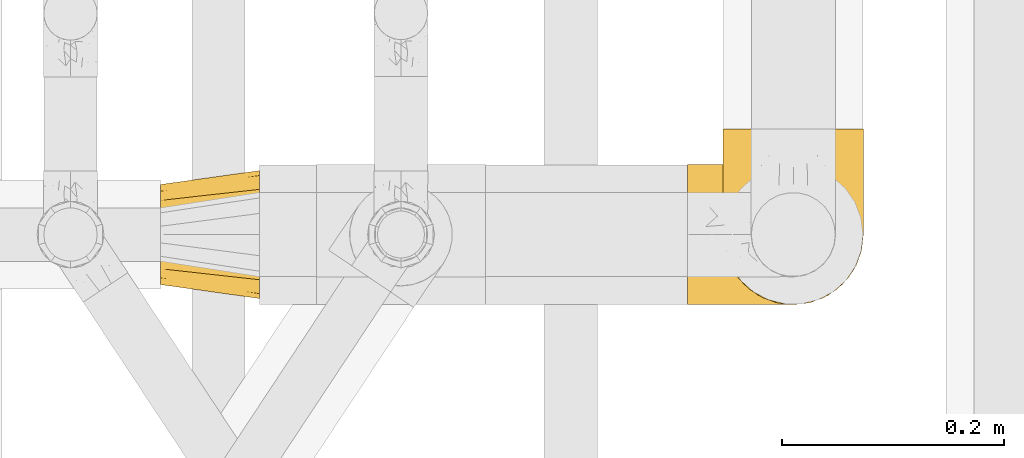
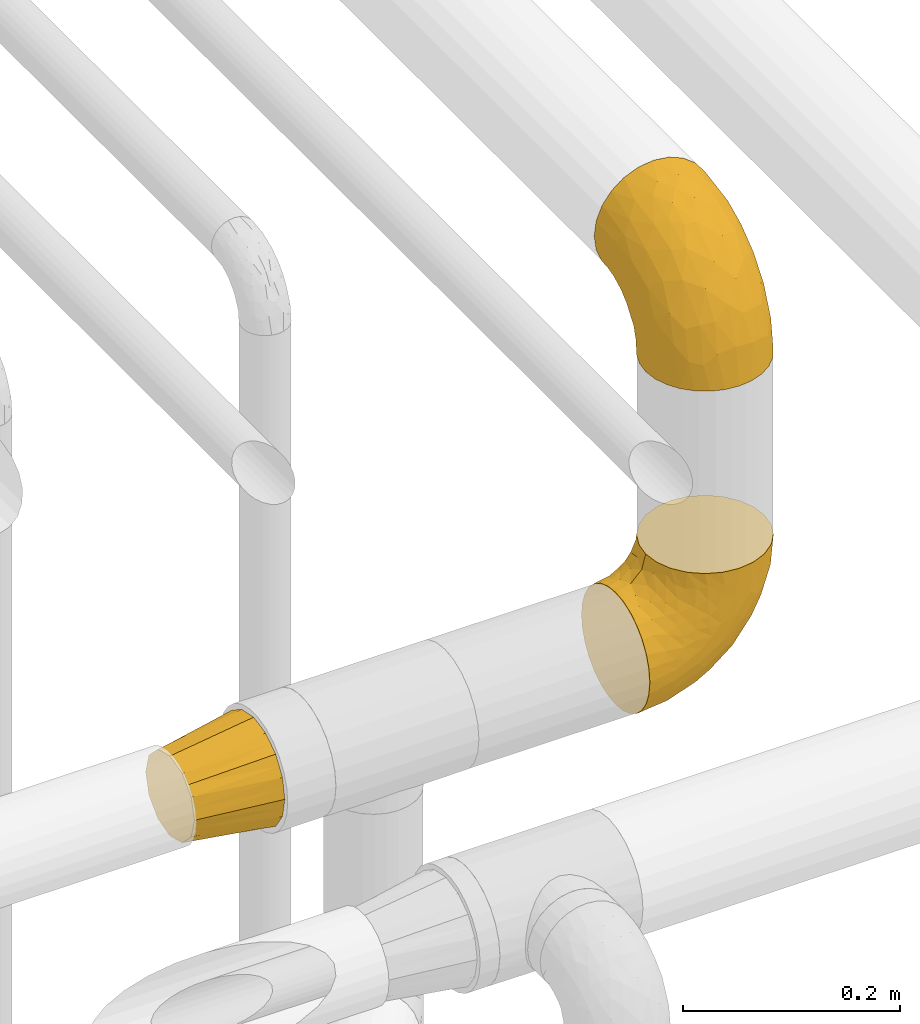
# One storey, part 389 of 827: 3 coverings.
"""IFC2X3 building model written with IfcOpenShell, lengths in millimetres."""

from ifc_helpers import new_model, entity, si_unit, converted_unit, derived_unit, direction, frame, origin, place, context, subcontext, project, spatial, faceted_brep, element, save


model = new_model("IFC2X3")

# Units and contexts
model_context = context("Model", 3, precision=0.01, world=origin(), true_north=direction((6.12303176911189e-17, 1.0)))
body_context = subcontext(model_context, "Body", "Model", "MODEL_VIEW")
ifc_project = project(units=[si_unit("LENGTHUNIT", "METRE", prefix="MILLI"), si_unit("AREAUNIT", "SQUARE_METRE"), si_unit("VOLUMEUNIT", "CUBIC_METRE"), converted_unit("PLANEANGLEUNIT", "DEGREE", entity("IfcRatioMeasure", 0.0174532925199433), si_unit("PLANEANGLEUNIT", "RADIAN"), dimensions=[0, 0, 0, 0, 0, 0, 0]), si_unit("MASSUNIT", "GRAM", prefix="KILO"), derived_unit("MASSDENSITYUNIT", [(si_unit("MASSUNIT", "GRAM", prefix="KILO"), 1), (si_unit("LENGTHUNIT", "METRE"), -3)]), derived_unit("MOMENTOFINERTIAUNIT", [(si_unit("LENGTHUNIT", "METRE"), 4)]), si_unit("TIMEUNIT", "SECOND"), si_unit("FREQUENCYUNIT", "HERTZ"), si_unit("THERMODYNAMICTEMPERATUREUNIT", "DEGREE_CELSIUS"), derived_unit("THERMALTRANSMITTANCEUNIT", [(si_unit("MASSUNIT", "GRAM", prefix="KILO"), 1), (si_unit("THERMODYNAMICTEMPERATUREUNIT", "KELVIN"), -1), (si_unit("TIMEUNIT", "SECOND"), -3)]), derived_unit("VOLUMETRICFLOWRATEUNIT", [(si_unit("LENGTHUNIT", "METRE"), 3), (si_unit("TIMEUNIT", "SECOND"), -1)]), derived_unit("MASSFLOWRATEUNIT", [(si_unit("MASSUNIT", "GRAM", prefix="KILO"), 1), (si_unit("TIMEUNIT", "SECOND"), -1)]), derived_unit("ROTATIONALFREQUENCYUNIT", [(si_unit("TIMEUNIT", "SECOND"), -1)]), si_unit("ELECTRICCURRENTUNIT", "AMPERE"), si_unit("ELECTRICVOLTAGEUNIT", "VOLT"), si_unit("POWERUNIT", "WATT"), si_unit("FORCEUNIT", "NEWTON", prefix="KILO"), si_unit("ILLUMINANCEUNIT", "LUX"), si_unit("LUMINOUSFLUXUNIT", "LUMEN"), si_unit("LUMINOUSINTENSITYUNIT", "CANDELA"), derived_unit("USERDEFINED", [(si_unit("MASSUNIT", "GRAM", prefix="KILO"), -1), (si_unit("LENGTHUNIT", "METRE"), -2), (si_unit("TIMEUNIT", "SECOND"), 3), (si_unit("LUMINOUSFLUXUNIT", "LUMEN"), 1)]), derived_unit("LINEARVELOCITYUNIT", [(si_unit("LENGTHUNIT", "METRE"), 1), (si_unit("TIMEUNIT", "SECOND"), -1)]), si_unit("PRESSUREUNIT", "PASCAL"), derived_unit("USERDEFINED", [(si_unit("LENGTHUNIT", "METRE"), -2), (si_unit("MASSUNIT", "GRAM", prefix="KILO"), 1), (si_unit("TIMEUNIT", "SECOND"), -2)]), derived_unit("LINEARFORCEUNIT", [(si_unit("MASSUNIT", "GRAM", prefix="KILO"), 1), (si_unit("LENGTHUNIT", "METRE"), 1), (si_unit("TIMEUNIT", "SECOND"), -2), (si_unit("LENGTHUNIT", "METRE"), -1)]), derived_unit("PLANARFORCEUNIT", [(si_unit("MASSUNIT", "GRAM", prefix="KILO"), 1), (si_unit("LENGTHUNIT", "METRE"), 1), (si_unit("TIMEUNIT", "SECOND"), -2), (si_unit("LENGTHUNIT", "METRE"), -2)])], contexts=[model_context])

# Site, building, storey
site_placement = place(None, origin())
site = spatial("IfcSite", under=ifc_project, at=site_placement, CompositionType="ELEMENT")
building_placement = place(site_placement, origin())
building = spatial("IfcBuilding", under=site, at=building_placement, CompositionType="ELEMENT")
storey_placement = place(building_placement, frame((0.0, 0.0, 28200.0)))
storey = spatial("IfcBuildingStorey", under=building, at=storey_placement, Name="08", CompositionType="ELEMENT", Elevation=28200.0)

# Coverings
covering_1_placement = place(storey_placement, frame((48580.2, 14171.03, 2903.4)))
element("IfcCovering", 1, at=covering_1_placement, inside=storey, Name=":ADSK_", ObjectType=":ADSK_", PredefinedType="INSULATION", context=body_context, shape_type="Brep", body=[
    faceted_brep([(126.11, 50.62, 1.6), (121.45, 37.29, 1.6), (113.94, 25.34, 1.6), (103.96, 15.35, 1.6), (92.0, 7.84, 1.6), (78.68, 3.18, 1.6), (64.65, 1.6, 1.6), (50.62, 3.18, 1.6), (37.29, 7.84, 1.6), (25.34, 15.35, 1.6), (15.35, 25.33, 1.6), (7.84, 37.29, 1.6), (3.18, 50.61, 1.6), (1.6, 64.65, 1.6), (3.18, 78.67, 1.6), (7.84, 92.0, 1.6), (15.35, 103.95, 1.6), (25.33, 113.94, 1.6), (37.29, 121.45, 1.6), (50.61, 126.11, 1.6), (64.65, 127.7, 1.6), (78.67, 126.11, 1.6), (92.0, 121.45, 1.6), (103.95, 113.94, 1.6), (113.94, 103.96, 1.6), (121.45, 92.0, 1.6), (126.11, 78.68, 1.6), (127.7, 64.65, 1.6), (64.65, 159.65, 33.55), (48.33, 159.65, 35.69), (33.12, 159.65, 41.99), (20.06, 159.65, 52.01), (10.04, 159.65, 65.07), (3.74, 159.65, 80.28), (3.01, 159.65, 85.89), (1.6, 159.65, 96.6), (3.74, 159.65, 112.91), (10.04, 159.65, 128.12), (20.06, 159.65, 141.18), (33.12, 159.65, 151.2), (48.33, 159.65, 157.5), (64.65, 159.65, 159.65), (80.96, 159.65, 157.5), (96.17, 159.65, 151.2), (109.23, 159.65, 141.18), (119.25, 159.65, 128.12), (125.55, 159.65, 112.91), (127.7, 159.65, 96.6), (126.29, 159.65, 85.89), (125.55, 159.65, 80.28), (119.25, 159.65, 65.07), (109.23, 159.65, 52.01), (96.17, 159.65, 41.99), (80.96, 159.65, 35.69), (101.1, 131.11, 145.23), (86.72, 121.84, 150.95), (98.7, 98.59, 136.48), (75.93, 132.73, 156.3), (64.65, 118.74, 154.26), (113.39, 45.67, 73.92), (111.06, 62.3, 98.94), (96.87, 49.95, 102.72), (84.07, 65.74, 124.89), (64.65, 80.62, 138.47), (64.65, 47.89, 113.35), (119.56, 117.53, 120.33), (112.75, 90.48, 118.42), (122.85, 98.53, 103.99), (125.08, 128.08, 110.05), (126.64, 107.83, 94.6), (105.78, 30.59, 62.68), (93.81, 23.56, 66.8), (96.07, 14.41, 37.71), (87.11, 94.66, 141.12), (75.77, 103.54, 148.29), (111.99, 121.36, 132.76), (64.65, 6.98, 42.5), (83.58, 9.17, 39.36), (80.96, 35.7, 96.16), (78.34, 18.43, 69.16), (122.85, 57.25, 62.71), (125.88, 81.84, 79.4), (120.97, 72.43, 88.81), (126.67, 56.38, 26.93), (122.64, 43.86, 32.13), (127.7, 103.81, 78.45), (127.7, 117.05, 85.2), (127.7, 130.29, 91.95), (107.12, 21.28, 31.66), (115.07, 34.21, 45.38), (102.81, 74.07, 118.88), (127.7, 82.79, 57.43), (127.7, 88.04, 62.69), (127.7, 93.3, 67.94), (127.7, 66.61, 13.99), (127.7, 67.95, 22.47), (127.7, 69.29, 30.95), (126.64, 66.64, 53.41), (127.7, 76.04, 44.19), (64.65, 22.77, 80.62), (127.7, 147.25, 94.63), (113.05, 120.78, 39.95), (101.81, 128.88, 33.15), (108.46, 132.53, 43.2), (126.21, 145.71, 81.77), (122.65, 132.18, 66.3), (126.55, 121.21, 75.23), (125.45, 115.88, 66.55), (126.01, 134.78, 78.18), (123.3, 113.68, 56.85), (118.99, 124.96, 54.23), (113.51, 105.67, 12.94), (104.6, 116.22, 17.42), (118.04, 103.69, 27.05), (101.6, 149.68, 44.37), (109.98, 142.04, 49.66), (92.1, 151.17, 38.88), (96.28, 140.2, 37.08), (121.05, 145.72, 66.96), (79.4, 147.4, 32.99), (79.19, 128.57, 14.52), (80.39, 136.38, 26.32), (93.14, 126.93, 22.37), (126.75, 79.77, 27.96), (125.71, 89.98, 39.47), (126.17, 79.6, 15.41), (64.65, 131.98, 17.57), (123.28, 90.59, 21.32), (64.65, 129.31, 7.61), (91.58, 133.25, 28.92), (107.1, 119.53, 28.65), (116.28, 111.1, 34.82), (116.32, 143.67, 58.27), (90.34, 123.62, 11.73), (122.74, 100.76, 40.36), (64.65, 143.67, 29.26), (126.77, 104.28, 65.12), (119.84, 112.26, 45.4), (124.71, 103.95, 53.05), (126.47, 92.99, 50.39), (37.19, 151.17, 38.88), (27.66, 144.66, 42.9), (49.9, 147.4, 32.99), (1.6, 147.25, 94.63), (50.1, 128.57, 14.52), (48.89, 136.38, 26.32), (2.88, 93.43, 50.51), (6.55, 100.15, 39.41), (3.58, 89.98, 39.47), (1.6, 103.81, 78.45), (1.6, 117.05, 85.2), (2.74, 121.21, 75.23), (11.25, 103.69, 27.05), (11.93, 110.23, 36.34), (21.09, 118.45, 28.89), (3.28, 134.78, 78.18), (6.64, 132.18, 66.3), (12.97, 143.67, 58.27), (19.31, 142.04, 49.66), (16.23, 120.78, 39.95), (21.44, 132.4, 42.42), (26.96, 127.76, 32.56), (8.24, 145.72, 66.96), (3.08, 145.71, 81.77), (10.3, 124.96, 54.23), (38.95, 123.62, 11.73), (33.01, 140.2, 37.08), (1.6, 66.61, 13.99), (1.6, 67.95, 22.47), (36.15, 126.93, 22.37), (24.69, 116.21, 17.42), (6.01, 90.59, 21.32), (2.54, 79.77, 27.96), (15.78, 105.66, 12.94), (1.6, 69.29, 30.95), (3.12, 79.6, 15.41), (37.33, 133.38, 29.3), (1.6, 82.79, 57.43), (1.6, 76.04, 44.19), (2.52, 104.28, 65.12), (3.84, 115.88, 66.55), (5.99, 113.68, 56.85), (9.35, 112.97, 46.41), (1.6, 93.3, 67.94), (4.58, 103.94, 53.04), (1.6, 130.29, 91.95), (30.59, 98.59, 136.48), (28.19, 131.11, 145.23), (17.3, 121.36, 132.76), (9.73, 117.53, 120.33), (42.57, 121.84, 150.95), (53.51, 105.45, 149.01), (53.42, 132.83, 156.33), (2.65, 107.83, 94.6), (2.62, 56.38, 26.93), (6.66, 43.85, 32.14), (6.44, 57.25, 62.71), (48.33, 35.7, 96.16), (32.42, 49.95, 102.72), (35.49, 23.55, 66.79), (2.65, 66.64, 53.41), (3.41, 81.84, 79.4), (4.21, 128.08, 110.05), (43.07, 92.46, 140.44), (23.52, 30.58, 62.68), (22.18, 21.27, 31.66), (33.1, 12.64, 29.31), (15.9, 45.66, 73.92), (14.23, 34.21, 45.39), (16.54, 90.48, 118.42), (45.22, 65.74, 124.89), (6.44, 98.53, 103.99), (8.33, 72.43, 88.81), (18.23, 62.3, 98.94), (32.99, 72.15, 122.85), (53.35, 82.52, 138.38), (48.76, 19.03, 69.18), (45.72, 9.17, 39.36)], [[[0, 1, 2, 3, 4, 5, 6, 7, 8, 9, 10, 11, 12, 13, 14, 15, 16, 17, 18, 19, 20, 21, 22, 23, 24, 25, 26, 27]], [[28, 29, 30, 31, 32, 33, 34, 35, 36, 37, 38, 39, 40, 41, 42, 43, 44, 45, 46, 47, 48, 49, 50, 51, 52, 53]], [[54, 55, 56]], [[57, 41, 58]], [[59, 60, 61]], [[62, 63, 64]], [[65, 66, 67]], [[68, 67, 69]], [[70, 71, 72]], [[55, 73, 56]], [[43, 42, 55]], [[55, 74, 73]], [[44, 75, 45]], [[44, 43, 54]], [[76, 5, 77]], [[71, 78, 79]], [[45, 75, 65]], [[46, 68, 47]], [[80, 81, 82]], [[0, 83, 84]], [[69, 85, 86, 87]], [[69, 81, 85]], [[84, 1, 0]], [[2, 88, 3]], [[4, 3, 72]], [[44, 54, 75]], [[5, 4, 77]], [[89, 2, 1]], [[72, 3, 88]], [[5, 76, 6]], [[70, 88, 89]], [[68, 65, 67]], [[88, 2, 89]], [[56, 90, 66]], [[64, 78, 62]], [[81, 91, 92, 93, 85]], [[83, 27, 94, 95, 96]], [[62, 61, 90]], [[97, 96, 98, 91]], [[80, 97, 81]], [[42, 57, 55]], [[62, 78, 61]], [[84, 89, 1]], [[78, 64, 99]], [[57, 74, 55]], [[76, 77, 79]], [[77, 72, 71]], [[82, 81, 67]], [[97, 83, 96]], [[80, 89, 84]], [[79, 78, 99]], [[71, 70, 61]], [[81, 97, 91]], [[83, 80, 84]], [[68, 87, 100, 47]], [[81, 69, 67]], [[68, 69, 87]], [[65, 46, 45]], [[65, 68, 46]], [[66, 65, 75]], [[56, 66, 75]], [[66, 60, 82]], [[71, 61, 78]], [[60, 66, 90]], [[83, 97, 80]], [[27, 83, 0]], [[59, 70, 89]], [[70, 59, 61]], [[89, 80, 59]], [[82, 59, 80]], [[55, 54, 43]], [[75, 54, 56]], [[66, 82, 67]], [[59, 82, 60]], [[41, 57, 42]], [[74, 57, 58]], [[58, 63, 74]], [[62, 74, 63]], [[74, 62, 73]], [[62, 56, 73]], [[4, 72, 77]], [[70, 72, 88]], [[76, 79, 99]], [[71, 79, 77]], [[62, 90, 56]], [[60, 90, 61]], [[101, 102, 103]], [[100, 87, 104]], [[105, 106, 107]], [[108, 104, 87]], [[107, 109, 110]], [[108, 87, 86]], [[111, 112, 113]], [[114, 51, 115]], [[116, 114, 117]], [[51, 50, 118]], [[119, 28, 53]], [[120, 121, 122]], [[98, 123, 124]], [[125, 96, 95]], [[116, 53, 52]], [[126, 121, 120]], [[104, 108, 118]], [[98, 124, 91]], [[25, 24, 127]], [[120, 128, 126]], [[122, 129, 102]], [[95, 94, 27, 26]], [[122, 102, 130]], [[125, 127, 123]], [[24, 111, 127]], [[21, 20, 128]], [[112, 130, 131]], [[48, 47, 100, 49]], [[132, 110, 115]], [[23, 111, 24]], [[129, 119, 117]], [[120, 133, 21]], [[112, 23, 22]], [[134, 113, 131]], [[121, 126, 135]], [[133, 112, 22]], [[128, 120, 21]], [[132, 51, 118]], [[120, 122, 133]], [[119, 121, 135]], [[129, 117, 102]], [[125, 26, 25]], [[26, 125, 95]], [[127, 125, 25]], [[28, 119, 135]], [[119, 53, 116]], [[127, 113, 124]], [[96, 125, 123]], [[112, 131, 113]], [[101, 103, 110]], [[85, 93, 136]], [[124, 123, 127]], [[98, 96, 123]], [[112, 111, 23]], [[127, 111, 113]], [[112, 133, 122]], [[21, 133, 22]], [[107, 110, 105]], [[110, 109, 137]], [[86, 106, 108]], [[138, 109, 136]], [[105, 118, 108]], [[107, 106, 85]], [[104, 50, 49]], [[124, 134, 139]], [[138, 93, 92]], [[92, 91, 139]], [[100, 104, 49]], [[118, 105, 132]], [[104, 118, 50]], [[110, 132, 105]], [[51, 132, 115]], [[108, 106, 105]], [[85, 106, 86]], [[114, 116, 52]], [[119, 116, 117]], [[51, 114, 52]], [[114, 115, 103]], [[117, 114, 103]], [[130, 102, 101]], [[117, 103, 102]], [[110, 103, 115]], [[130, 101, 131]], [[122, 130, 112]], [[101, 137, 131]], [[113, 134, 124]], [[137, 134, 131]], [[124, 139, 91]], [[134, 138, 139]], [[92, 139, 138]], [[110, 137, 101]], [[134, 137, 138]], [[136, 109, 107]], [[137, 109, 138]], [[85, 136, 107]], [[138, 136, 93]], [[122, 121, 129]], [[129, 121, 119]], [[30, 140, 141]], [[30, 29, 140]], [[28, 135, 142]], [[143, 35, 34, 33]], [[19, 144, 128]], [[126, 145, 135]], [[146, 147, 148]], [[149, 150, 151]], [[152, 153, 154]], [[155, 156, 151]], [[157, 31, 158]], [[159, 160, 161]], [[32, 162, 163]], [[158, 31, 30]], [[157, 164, 156]], [[126, 144, 145]], [[126, 128, 144]], [[18, 165, 19]], [[141, 166, 160]], [[14, 13, 167, 168]], [[163, 143, 33]], [[169, 165, 170]], [[18, 17, 170]], [[153, 159, 154]], [[142, 135, 145]], [[148, 171, 172]], [[159, 161, 154]], [[171, 152, 173]], [[173, 17, 16]], [[16, 15, 171]], [[158, 160, 164]], [[174, 175, 168]], [[173, 170, 17]], [[19, 128, 20]], [[174, 172, 175]], [[165, 169, 144]], [[162, 157, 156]], [[175, 172, 171]], [[144, 169, 145]], [[176, 169, 161]], [[166, 140, 142]], [[175, 171, 15]], [[168, 175, 14]], [[14, 175, 15]], [[142, 145, 176]], [[28, 142, 29]], [[148, 177, 146]], [[148, 178, 177]], [[152, 171, 148]], [[179, 180, 181]], [[164, 180, 156]], [[174, 178, 172]], [[148, 172, 178]], [[171, 173, 16]], [[170, 173, 152]], [[19, 165, 144]], [[170, 165, 18]], [[153, 182, 159]], [[146, 183, 184]], [[181, 180, 164]], [[180, 151, 156]], [[163, 155, 185]], [[155, 150, 185]], [[162, 156, 155]], [[143, 163, 185]], [[180, 179, 149]], [[32, 163, 33]], [[163, 162, 155]], [[31, 162, 32]], [[31, 157, 162]], [[164, 157, 158]], [[149, 151, 180]], [[155, 151, 150]], [[142, 140, 29]], [[141, 140, 166]], [[176, 145, 169]], [[30, 141, 158]], [[164, 160, 159]], [[158, 141, 160]], [[166, 161, 160]], [[154, 169, 170]], [[169, 154, 161]], [[152, 154, 170]], [[147, 152, 148]], [[153, 147, 182]], [[181, 182, 184]], [[164, 159, 182]], [[161, 166, 176]], [[142, 176, 166]], [[183, 146, 177]], [[184, 182, 147]], [[184, 147, 146]], [[152, 147, 153]], [[182, 181, 164]], [[179, 184, 183]], [[184, 179, 181]], [[149, 179, 183]], [[186, 187, 188]], [[37, 36, 189]], [[190, 191, 192]], [[193, 185, 150, 149]], [[194, 195, 196]], [[197, 198, 199]], [[200, 201, 177]], [[193, 202, 185]], [[203, 190, 186]], [[202, 189, 36]], [[41, 40, 192]], [[204, 205, 199]], [[9, 8, 206]], [[187, 190, 39]], [[40, 39, 190]], [[38, 37, 188]], [[207, 208, 204]], [[202, 35, 143, 185]], [[39, 38, 187]], [[195, 11, 208]], [[201, 149, 183, 177]], [[188, 189, 209]], [[197, 64, 210]], [[186, 188, 209]], [[13, 12, 194]], [[211, 201, 212]], [[12, 11, 195]], [[193, 201, 211]], [[212, 201, 196]], [[10, 208, 11]], [[213, 214, 209]], [[64, 63, 215]], [[216, 197, 199]], [[8, 217, 206]], [[7, 217, 8]], [[203, 191, 190]], [[7, 6, 76]], [[208, 205, 204]], [[205, 10, 9]], [[199, 205, 206]], [[7, 76, 217]], [[205, 208, 10]], [[216, 76, 99]], [[200, 177, 178, 174]], [[64, 197, 99]], [[63, 58, 191]], [[208, 196, 195]], [[196, 200, 194]], [[198, 197, 210]], [[216, 199, 217]], [[201, 193, 149]], [[202, 193, 211]], [[202, 211, 189]], [[35, 202, 36]], [[211, 212, 209]], [[37, 189, 188]], [[211, 209, 189]], [[213, 198, 214]], [[200, 174, 194]], [[201, 200, 196]], [[214, 198, 210]], [[213, 207, 198]], [[194, 174, 168, 167, 13]], [[195, 194, 12]], [[198, 204, 199]], [[204, 198, 207]], [[212, 207, 213]], [[196, 208, 207]], [[188, 187, 38]], [[190, 187, 186]], [[207, 212, 196]], [[209, 212, 213]], [[214, 203, 186]], [[191, 215, 63]], [[191, 203, 215]], [[192, 191, 58]], [[41, 192, 58]], [[190, 192, 40]], [[203, 210, 215]], [[64, 215, 210]], [[199, 206, 217]], [[9, 206, 205]], [[76, 216, 217]], [[99, 197, 216]], [[203, 214, 210]], [[209, 214, 186]]]),
])
covering_2_placement = place(storey_placement, frame((48548.25, 14171.03, 2540.35)))
element("IfcCovering", 2, at=covering_2_placement, inside=storey, Name=":ADSK_", ObjectType=":ADSK_", PredefinedType="INSULATION", context=body_context, shape_type="Brep", body=[
    faceted_brep([(1.6, 126.11, 50.62), (1.6, 121.45, 37.29), (1.6, 113.94, 25.34), (1.6, 103.96, 15.35), (1.6, 92.0, 7.84), (1.6, 78.68, 3.18), (1.6, 64.65, 1.6), (1.6, 50.62, 3.18), (1.6, 37.29, 7.84), (1.6, 25.34, 15.35), (1.6, 15.35, 25.33), (1.6, 7.84, 37.29), (1.6, 3.18, 50.61), (1.6, 1.6, 64.65), (1.6, 3.18, 78.67), (1.6, 7.84, 92.0), (1.6, 15.35, 103.95), (1.6, 25.33, 113.94), (1.6, 37.29, 121.45), (1.6, 50.61, 126.11), (1.6, 64.65, 127.7), (1.6, 78.67, 126.11), (1.6, 92.0, 121.45), (1.6, 103.95, 113.94), (1.6, 113.94, 103.96), (1.6, 121.45, 92.0), (1.6, 126.11, 78.68), (1.6, 127.7, 64.65), (33.55, 64.65, 159.65), (35.69, 48.33, 159.65), (41.99, 33.12, 159.65), (52.01, 20.06, 159.65), (65.07, 10.04, 159.65), (80.28, 3.74, 159.65), (85.89, 3.01, 159.65), (96.6, 1.6, 159.65), (112.91, 3.74, 159.65), (128.12, 10.04, 159.65), (141.18, 20.06, 159.65), (151.2, 33.12, 159.65), (157.5, 48.33, 159.65), (159.65, 64.65, 159.65), (157.5, 80.96, 159.65), (151.2, 96.17, 159.65), (141.18, 109.23, 159.65), (128.12, 119.25, 159.65), (112.91, 125.55, 159.65), (96.6, 127.7, 159.65), (85.89, 126.29, 159.65), (80.28, 125.55, 159.65), (65.07, 119.25, 159.65), (52.01, 109.23, 159.65), (41.99, 96.17, 159.65), (35.69, 80.96, 159.65), (145.23, 101.1, 131.11), (150.95, 86.72, 121.84), (136.48, 98.7, 98.59), (156.3, 75.93, 132.73), (154.26, 64.65, 118.74), (73.92, 113.39, 45.67), (98.94, 111.06, 62.3), (102.72, 96.87, 49.95), (124.89, 84.07, 65.74), (138.47, 64.65, 80.62), (113.35, 64.65, 47.89), (120.33, 119.56, 117.53), (118.42, 112.75, 90.48), (103.99, 122.85, 98.53), (110.05, 125.08, 128.08), (94.6, 126.64, 107.83), (62.68, 105.78, 30.59), (66.8, 93.81, 23.56), (37.71, 96.07, 14.41), (141.12, 87.11, 94.66), (148.29, 75.77, 103.54), (132.76, 111.99, 121.36), (42.5, 64.65, 6.98), (39.36, 83.58, 9.17), (96.16, 80.96, 35.7), (69.16, 78.34, 18.43), (62.71, 122.85, 57.25), (79.4, 125.88, 81.84), (88.81, 120.97, 72.43), (26.93, 126.67, 56.38), (32.13, 122.64, 43.86), (78.45, 127.7, 103.81), (85.2, 127.7, 117.05), (91.95, 127.7, 130.29), (31.66, 107.12, 21.28), (45.38, 115.07, 34.21), (118.88, 102.81, 74.07), (57.43, 127.7, 82.79), (62.69, 127.7, 88.04), (67.94, 127.7, 93.3), (13.99, 127.7, 66.61), (22.47, 127.7, 67.95), (30.95, 127.7, 69.29), (53.41, 126.64, 66.64), (44.19, 127.7, 76.04), (80.62, 64.65, 22.77), (94.63, 127.7, 147.25), (39.95, 113.05, 120.78), (33.15, 101.81, 128.88), (43.2, 108.46, 132.53), (81.77, 126.21, 145.71), (66.3, 122.65, 132.18), (75.23, 126.55, 121.21), (66.55, 125.45, 115.88), (78.18, 126.01, 134.78), (56.85, 123.3, 113.68), (54.23, 118.99, 124.96), (12.94, 113.51, 105.67), (17.42, 104.6, 116.22), (27.05, 118.04, 103.69), (44.37, 101.6, 149.68), (49.66, 109.98, 142.04), (38.88, 92.1, 151.17), (37.08, 96.28, 140.2), (66.96, 121.05, 145.72), (32.99, 79.4, 147.4), (14.52, 79.19, 128.57), (26.32, 80.39, 136.38), (22.37, 93.14, 126.93), (27.96, 126.75, 79.77), (39.47, 125.71, 89.98), (15.41, 126.17, 79.6), (17.57, 64.65, 131.98), (21.32, 123.28, 90.59), (7.61, 64.65, 129.31), (28.92, 91.58, 133.25), (28.65, 107.1, 119.53), (34.82, 116.28, 111.1), (58.27, 116.32, 143.67), (11.73, 90.34, 123.62), (40.36, 122.74, 100.76), (29.26, 64.65, 143.67), (65.12, 126.77, 104.28), (45.4, 119.84, 112.26), (53.05, 124.71, 103.95), (50.39, 126.47, 92.99), (38.88, 37.19, 151.17), (42.9, 27.66, 144.66), (32.99, 49.9, 147.4), (94.63, 1.6, 147.25), (14.52, 50.1, 128.57), (26.32, 48.89, 136.38), (50.51, 2.88, 93.43), (39.41, 6.55, 100.15), (39.47, 3.58, 89.98), (78.45, 1.6, 103.81), (85.2, 1.6, 117.05), (75.23, 2.74, 121.21), (27.05, 11.25, 103.69), (36.34, 11.93, 110.23), (28.89, 21.09, 118.45), (78.18, 3.28, 134.78), (66.3, 6.64, 132.18), (58.27, 12.97, 143.67), (49.66, 19.31, 142.04), (39.95, 16.23, 120.78), (42.42, 21.44, 132.4), (32.56, 26.96, 127.76), (66.96, 8.24, 145.72), (81.77, 3.08, 145.71), (54.23, 10.3, 124.96), (11.73, 38.95, 123.62), (37.08, 33.01, 140.2), (13.99, 1.6, 66.61), (22.47, 1.6, 67.95), (22.37, 36.15, 126.93), (17.42, 24.69, 116.21), (21.32, 6.01, 90.59), (27.96, 2.54, 79.77), (12.94, 15.78, 105.66), (30.95, 1.6, 69.29), (15.41, 3.12, 79.6), (29.3, 37.33, 133.38), (57.43, 1.6, 82.79), (44.19, 1.6, 76.04), (65.12, 2.52, 104.28), (66.55, 3.84, 115.88), (56.85, 5.99, 113.68), (46.41, 9.35, 112.97), (67.94, 1.6, 93.3), (53.04, 4.58, 103.94), (91.95, 1.6, 130.29), (136.48, 30.59, 98.59), (145.23, 28.19, 131.11), (132.76, 17.3, 121.36), (120.33, 9.73, 117.53), (150.95, 42.57, 121.84), (149.01, 53.51, 105.45), (156.33, 53.42, 132.83), (94.6, 2.65, 107.83), (26.93, 2.62, 56.38), (32.14, 6.66, 43.85), (62.71, 6.44, 57.25), (96.16, 48.33, 35.7), (102.72, 32.42, 49.95), (66.79, 35.49, 23.55), (53.41, 2.65, 66.64), (79.4, 3.41, 81.84), (110.05, 4.21, 128.08), (140.44, 43.07, 92.46), (62.68, 23.52, 30.58), (31.66, 22.18, 21.27), (29.31, 33.1, 12.64), (73.92, 15.9, 45.66), (45.39, 14.23, 34.21), (118.42, 16.54, 90.48), (124.89, 45.22, 65.74), (103.99, 6.44, 98.53), (88.81, 8.33, 72.43), (98.94, 18.23, 62.3), (122.85, 32.99, 72.15), (138.38, 53.35, 82.52), (69.18, 48.76, 19.03), (39.36, 45.72, 9.17)], [[[0, 1, 2, 3, 4, 5, 6, 7, 8, 9, 10, 11, 12, 13, 14, 15, 16, 17, 18, 19, 20, 21, 22, 23, 24, 25, 26, 27]], [[28, 29, 30, 31, 32, 33, 34, 35, 36, 37, 38, 39, 40, 41, 42, 43, 44, 45, 46, 47, 48, 49, 50, 51, 52, 53]], [[54, 55, 56]], [[57, 41, 58]], [[59, 60, 61]], [[62, 63, 64]], [[65, 66, 67]], [[68, 67, 69]], [[70, 71, 72]], [[55, 73, 56]], [[43, 42, 55]], [[55, 74, 73]], [[44, 75, 45]], [[44, 43, 54]], [[76, 5, 77]], [[71, 78, 79]], [[45, 75, 65]], [[46, 68, 47]], [[80, 81, 82]], [[0, 83, 84]], [[69, 85, 86, 87]], [[69, 81, 85]], [[84, 1, 0]], [[2, 88, 3]], [[4, 3, 72]], [[44, 54, 75]], [[5, 4, 77]], [[89, 2, 1]], [[72, 3, 88]], [[5, 76, 6]], [[70, 88, 89]], [[68, 65, 67]], [[88, 2, 89]], [[56, 90, 66]], [[64, 78, 62]], [[81, 91, 92, 93, 85]], [[83, 27, 94, 95, 96]], [[62, 61, 90]], [[97, 96, 98, 91]], [[80, 97, 81]], [[42, 57, 55]], [[62, 78, 61]], [[84, 89, 1]], [[78, 64, 99]], [[57, 74, 55]], [[76, 77, 79]], [[77, 72, 71]], [[82, 81, 67]], [[97, 83, 96]], [[80, 89, 84]], [[79, 78, 99]], [[71, 70, 61]], [[81, 97, 91]], [[83, 80, 84]], [[68, 87, 100, 47]], [[81, 69, 67]], [[68, 69, 87]], [[65, 46, 45]], [[65, 68, 46]], [[66, 65, 75]], [[56, 66, 75]], [[66, 60, 82]], [[71, 61, 78]], [[60, 66, 90]], [[83, 97, 80]], [[27, 83, 0]], [[59, 70, 89]], [[70, 59, 61]], [[89, 80, 59]], [[82, 59, 80]], [[55, 54, 43]], [[75, 54, 56]], [[66, 82, 67]], [[59, 82, 60]], [[41, 57, 42]], [[74, 57, 58]], [[58, 63, 74]], [[62, 74, 63]], [[74, 62, 73]], [[62, 56, 73]], [[4, 72, 77]], [[70, 72, 88]], [[76, 79, 99]], [[71, 79, 77]], [[62, 90, 56]], [[60, 90, 61]], [[101, 102, 103]], [[100, 87, 104]], [[105, 106, 107]], [[108, 104, 87]], [[107, 109, 110]], [[108, 87, 86]], [[111, 112, 113]], [[114, 51, 115]], [[116, 114, 117]], [[51, 50, 118]], [[119, 28, 53]], [[120, 121, 122]], [[98, 123, 124]], [[125, 96, 95]], [[116, 53, 52]], [[126, 121, 120]], [[104, 108, 118]], [[98, 124, 91]], [[25, 24, 127]], [[120, 128, 126]], [[122, 129, 102]], [[95, 94, 27, 26]], [[122, 102, 130]], [[125, 127, 123]], [[24, 111, 127]], [[21, 20, 128]], [[112, 130, 131]], [[48, 47, 100, 49]], [[132, 110, 115]], [[23, 111, 24]], [[129, 119, 117]], [[120, 133, 21]], [[112, 23, 22]], [[134, 113, 131]], [[121, 126, 135]], [[133, 112, 22]], [[128, 120, 21]], [[132, 51, 118]], [[120, 122, 133]], [[119, 121, 135]], [[129, 117, 102]], [[125, 26, 25]], [[26, 125, 95]], [[127, 125, 25]], [[28, 119, 135]], [[119, 53, 116]], [[127, 113, 124]], [[96, 125, 123]], [[112, 131, 113]], [[101, 103, 110]], [[85, 93, 136]], [[124, 123, 127]], [[98, 96, 123]], [[112, 111, 23]], [[127, 111, 113]], [[112, 133, 122]], [[21, 133, 22]], [[107, 110, 105]], [[110, 109, 137]], [[86, 106, 108]], [[138, 109, 136]], [[105, 118, 108]], [[107, 106, 85]], [[104, 50, 49]], [[124, 134, 139]], [[138, 93, 92]], [[92, 91, 139]], [[100, 104, 49]], [[118, 105, 132]], [[104, 118, 50]], [[110, 132, 105]], [[51, 132, 115]], [[108, 106, 105]], [[85, 106, 86]], [[114, 116, 52]], [[119, 116, 117]], [[51, 114, 52]], [[114, 115, 103]], [[117, 114, 103]], [[130, 102, 101]], [[117, 103, 102]], [[110, 103, 115]], [[130, 101, 131]], [[122, 130, 112]], [[101, 137, 131]], [[113, 134, 124]], [[137, 134, 131]], [[124, 139, 91]], [[134, 138, 139]], [[92, 139, 138]], [[110, 137, 101]], [[134, 137, 138]], [[136, 109, 107]], [[137, 109, 138]], [[85, 136, 107]], [[138, 136, 93]], [[122, 121, 129]], [[129, 121, 119]], [[30, 140, 141]], [[30, 29, 140]], [[28, 135, 142]], [[143, 35, 34, 33]], [[19, 144, 128]], [[126, 145, 135]], [[146, 147, 148]], [[149, 150, 151]], [[152, 153, 154]], [[155, 156, 151]], [[157, 31, 158]], [[159, 160, 161]], [[32, 162, 163]], [[158, 31, 30]], [[157, 164, 156]], [[126, 144, 145]], [[126, 128, 144]], [[18, 165, 19]], [[141, 166, 160]], [[14, 13, 167, 168]], [[163, 143, 33]], [[169, 165, 170]], [[18, 17, 170]], [[153, 159, 154]], [[142, 135, 145]], [[148, 171, 172]], [[159, 161, 154]], [[171, 152, 173]], [[173, 17, 16]], [[16, 15, 171]], [[158, 160, 164]], [[174, 175, 168]], [[173, 170, 17]], [[19, 128, 20]], [[174, 172, 175]], [[165, 169, 144]], [[162, 157, 156]], [[175, 172, 171]], [[144, 169, 145]], [[176, 169, 161]], [[166, 140, 142]], [[175, 171, 15]], [[168, 175, 14]], [[14, 175, 15]], [[142, 145, 176]], [[28, 142, 29]], [[148, 177, 146]], [[148, 178, 177]], [[152, 171, 148]], [[179, 180, 181]], [[164, 180, 156]], [[174, 178, 172]], [[148, 172, 178]], [[171, 173, 16]], [[170, 173, 152]], [[19, 165, 144]], [[170, 165, 18]], [[153, 182, 159]], [[146, 183, 184]], [[181, 180, 164]], [[180, 151, 156]], [[163, 155, 185]], [[155, 150, 185]], [[162, 156, 155]], [[143, 163, 185]], [[180, 179, 149]], [[32, 163, 33]], [[163, 162, 155]], [[31, 162, 32]], [[31, 157, 162]], [[164, 157, 158]], [[149, 151, 180]], [[155, 151, 150]], [[142, 140, 29]], [[141, 140, 166]], [[176, 145, 169]], [[30, 141, 158]], [[164, 160, 159]], [[158, 141, 160]], [[166, 161, 160]], [[154, 169, 170]], [[169, 154, 161]], [[152, 154, 170]], [[147, 152, 148]], [[153, 147, 182]], [[181, 182, 184]], [[164, 159, 182]], [[161, 166, 176]], [[142, 176, 166]], [[183, 146, 177]], [[184, 182, 147]], [[184, 147, 146]], [[152, 147, 153]], [[182, 181, 164]], [[179, 184, 183]], [[184, 179, 181]], [[149, 179, 183]], [[186, 187, 188]], [[37, 36, 189]], [[190, 191, 192]], [[193, 185, 150, 149]], [[194, 195, 196]], [[197, 198, 199]], [[200, 201, 177]], [[193, 202, 185]], [[203, 190, 186]], [[202, 189, 36]], [[41, 40, 192]], [[204, 205, 199]], [[9, 8, 206]], [[187, 190, 39]], [[40, 39, 190]], [[38, 37, 188]], [[207, 208, 204]], [[202, 35, 143, 185]], [[39, 38, 187]], [[195, 11, 208]], [[201, 149, 183, 177]], [[188, 189, 209]], [[197, 64, 210]], [[186, 188, 209]], [[13, 12, 194]], [[211, 201, 212]], [[12, 11, 195]], [[193, 201, 211]], [[212, 201, 196]], [[10, 208, 11]], [[213, 214, 209]], [[64, 63, 215]], [[216, 197, 199]], [[8, 217, 206]], [[7, 217, 8]], [[203, 191, 190]], [[7, 6, 76]], [[208, 205, 204]], [[205, 10, 9]], [[199, 205, 206]], [[7, 76, 217]], [[205, 208, 10]], [[216, 76, 99]], [[200, 177, 178, 174]], [[64, 197, 99]], [[63, 58, 191]], [[208, 196, 195]], [[196, 200, 194]], [[198, 197, 210]], [[216, 199, 217]], [[201, 193, 149]], [[202, 193, 211]], [[202, 211, 189]], [[35, 202, 36]], [[211, 212, 209]], [[37, 189, 188]], [[211, 209, 189]], [[213, 198, 214]], [[200, 174, 194]], [[201, 200, 196]], [[214, 198, 210]], [[213, 207, 198]], [[194, 174, 168, 167, 13]], [[195, 194, 12]], [[198, 204, 199]], [[204, 198, 207]], [[212, 207, 213]], [[196, 208, 207]], [[188, 187, 38]], [[190, 187, 186]], [[207, 212, 196]], [[209, 212, 213]], [[214, 203, 186]], [[191, 215, 63]], [[191, 203, 215]], [[192, 191, 58]], [[41, 192, 58]], [[190, 192, 40]], [[203, 210, 215]], [[64, 215, 210]], [[199, 206, 217]], [[9, 206, 205]], [[76, 216, 217]], [[99, 197, 216]], [[203, 214, 210]], [[209, 214, 186]]]),
])
covering_3_placement = place(storey_placement, frame((48075.84, 14176.58, 2545.9)))
element("IfcCovering", 3, at=covering_3_placement, inside=storey, Name=":ADSK_", ObjectType=":ADSK_", PredefinedType="INSULATION", context=body_context, shape_type="Brep", body=[
    faceted_brep([(0.0, 104.1, 59.1), (0.0, 101.08, 47.85), (0.0, 98.07, 36.6), (0.0, 89.83, 28.36), (0.0, 81.6, 20.12), (0.0, 70.35, 17.11), (0.0, 59.1, 14.1), (0.0, 47.85, 17.11), (0.0, 36.6, 20.12), (0.0, 28.36, 28.36), (0.0, 20.12, 36.6), (0.0, 17.11, 47.85), (0.0, 14.1, 59.1), (0.0, 17.11, 70.35), (0.0, 20.12, 81.6), (0.0, 28.36, 89.83), (0.0, 36.6, 98.07), (0.0, 47.85, 101.08), (0.0, 59.1, 104.1), (0.0, 70.35, 101.08), (0.0, 81.6, 98.07), (0.0, 89.83, 89.83), (0.0, 98.07, 81.6), (0.0, 101.08, 70.35), (89.0, 5.97, 81.1), (89.0, 3.78, 70.1), (89.0, 1.6, 59.1), (89.0, 3.78, 48.09), (89.0, 5.97, 37.09), (89.0, 12.2, 27.76), (89.0, 18.44, 18.44), (89.0, 27.76, 12.2), (89.0, 37.09, 5.97), (89.0, 48.09, 3.78), (89.0, 59.1, 1.6), (89.0, 70.1, 3.78), (89.0, 81.1, 5.97), (89.0, 90.43, 12.2), (89.0, 99.75, 18.44), (89.0, 105.99, 27.76), (89.0, 112.22, 37.09), (89.0, 114.41, 48.09), (89.0, 116.6, 59.1), (89.0, 114.41, 70.1), (89.0, 112.22, 81.1), (89.0, 105.99, 90.43), (89.0, 99.75, 99.75), (89.0, 90.43, 105.99), (89.0, 81.1, 112.22), (89.0, 70.1, 114.41), (89.0, 59.1, 116.6), (89.0, 48.09, 114.41), (89.0, 37.09, 112.22), (89.0, 27.76, 105.99), (89.0, 18.44, 99.75), (89.0, 12.2, 90.43)], [[[0, 1, 2, 3, 4, 5, 6, 7, 8, 9, 10, 11, 12, 13, 14, 15, 16, 17, 18, 19, 20, 21, 22, 23]], [[24, 25, 26, 27, 28, 29, 30, 31, 32, 33, 34, 35, 36, 37, 38, 39, 40, 41, 42, 43, 44, 45, 46, 47, 48, 49, 50, 51, 52, 53, 54, 55]], [[35, 34, 6]], [[2, 40, 39]], [[37, 36, 4]], [[37, 4, 3]], [[2, 39, 3]], [[37, 3, 38]], [[41, 40, 1]], [[6, 5, 35]], [[39, 38, 3]], [[0, 41, 1]], [[5, 4, 36]], [[41, 0, 42]], [[40, 2, 1]], [[5, 36, 35]], [[27, 26, 12]], [[8, 32, 31]], [[29, 28, 10]], [[29, 10, 9]], [[8, 31, 9]], [[29, 9, 30]], [[33, 32, 7]], [[12, 11, 27]], [[31, 30, 9]], [[6, 33, 7]], [[11, 10, 28]], [[33, 6, 34]], [[32, 8, 7]], [[11, 28, 27]], [[51, 50, 18]], [[14, 24, 55]], [[53, 52, 16]], [[53, 16, 15]], [[14, 55, 15]], [[53, 15, 54]], [[25, 24, 13]], [[18, 17, 51]], [[55, 54, 15]], [[12, 25, 13]], [[17, 16, 52]], [[25, 12, 26]], [[24, 14, 13]], [[17, 52, 51]], [[43, 42, 0]], [[20, 48, 47]], [[45, 44, 22]], [[45, 22, 21]], [[20, 47, 21]], [[45, 21, 46]], [[49, 48, 19]], [[0, 23, 43]], [[47, 46, 21]], [[18, 49, 19]], [[23, 22, 44]], [[49, 18, 50]], [[48, 20, 19]], [[23, 44, 43]]]),
])

save(model, "model.ifc")
